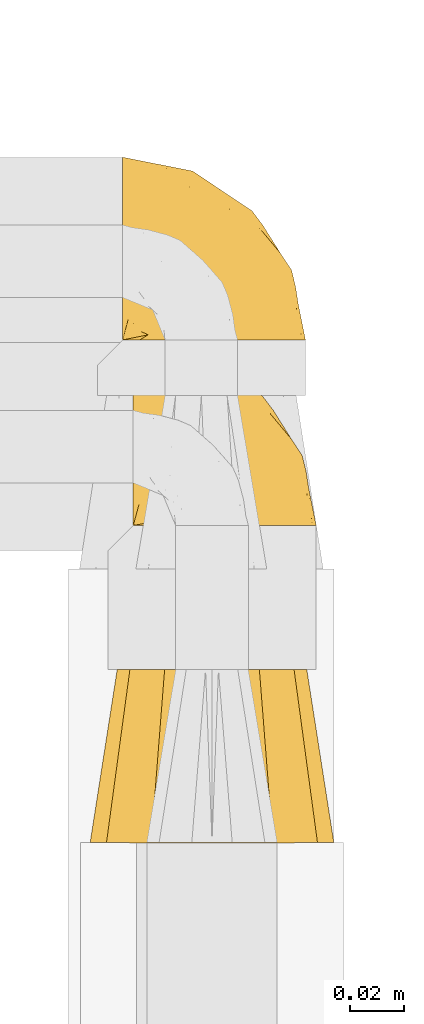
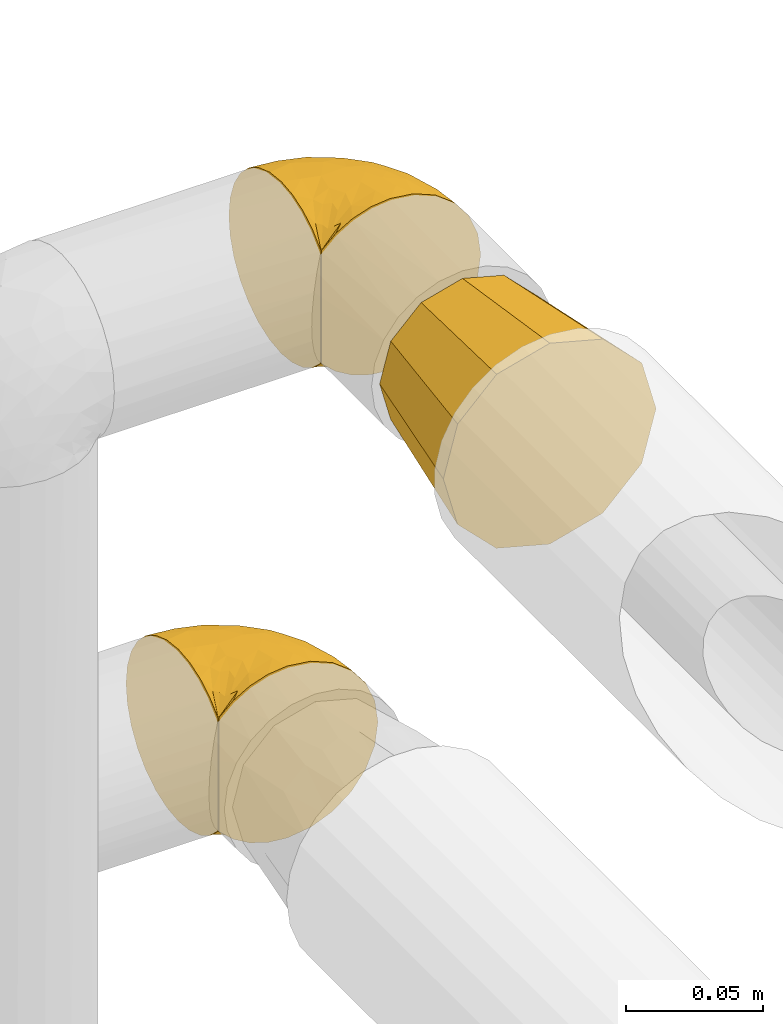
# One storey, part 116 of 827: 3 coverings.
"""IFC2X3 building model written with IfcOpenShell, lengths in millimetres."""

from ifc_helpers import new_model, entity, si_unit, converted_unit, derived_unit, direction, frame, origin, place, context, subcontext, project, spatial, faceted_brep, element, save


model = new_model("IFC2X3")

# Units and contexts
model_context = context("Model", 3, precision=0.01, world=origin(), true_north=direction((6.12303176911189e-17, 1.0)))
body_context = subcontext(model_context, "Body", "Model", "MODEL_VIEW")
ifc_project = project(units=[si_unit("LENGTHUNIT", "METRE", prefix="MILLI"), si_unit("AREAUNIT", "SQUARE_METRE"), si_unit("VOLUMEUNIT", "CUBIC_METRE"), converted_unit("PLANEANGLEUNIT", "DEGREE", entity("IfcRatioMeasure", 0.0174532925199433), si_unit("PLANEANGLEUNIT", "RADIAN"), dimensions=[0, 0, 0, 0, 0, 0, 0]), si_unit("MASSUNIT", "GRAM", prefix="KILO"), derived_unit("MASSDENSITYUNIT", [(si_unit("MASSUNIT", "GRAM", prefix="KILO"), 1), (si_unit("LENGTHUNIT", "METRE"), -3)]), derived_unit("MOMENTOFINERTIAUNIT", [(si_unit("LENGTHUNIT", "METRE"), 4)]), si_unit("TIMEUNIT", "SECOND"), si_unit("FREQUENCYUNIT", "HERTZ"), si_unit("THERMODYNAMICTEMPERATUREUNIT", "DEGREE_CELSIUS"), derived_unit("THERMALTRANSMITTANCEUNIT", [(si_unit("MASSUNIT", "GRAM", prefix="KILO"), 1), (si_unit("THERMODYNAMICTEMPERATUREUNIT", "KELVIN"), -1), (si_unit("TIMEUNIT", "SECOND"), -3)]), derived_unit("VOLUMETRICFLOWRATEUNIT", [(si_unit("LENGTHUNIT", "METRE"), 3), (si_unit("TIMEUNIT", "SECOND"), -1)]), derived_unit("MASSFLOWRATEUNIT", [(si_unit("MASSUNIT", "GRAM", prefix="KILO"), 1), (si_unit("TIMEUNIT", "SECOND"), -1)]), derived_unit("ROTATIONALFREQUENCYUNIT", [(si_unit("TIMEUNIT", "SECOND"), -1)]), si_unit("ELECTRICCURRENTUNIT", "AMPERE"), si_unit("ELECTRICVOLTAGEUNIT", "VOLT"), si_unit("POWERUNIT", "WATT"), si_unit("FORCEUNIT", "NEWTON", prefix="KILO"), si_unit("ILLUMINANCEUNIT", "LUX"), si_unit("LUMINOUSFLUXUNIT", "LUMEN"), si_unit("LUMINOUSINTENSITYUNIT", "CANDELA"), derived_unit("USERDEFINED", [(si_unit("MASSUNIT", "GRAM", prefix="KILO"), -1), (si_unit("LENGTHUNIT", "METRE"), -2), (si_unit("TIMEUNIT", "SECOND"), 3), (si_unit("LUMINOUSFLUXUNIT", "LUMEN"), 1)]), derived_unit("LINEARVELOCITYUNIT", [(si_unit("LENGTHUNIT", "METRE"), 1), (si_unit("TIMEUNIT", "SECOND"), -1)]), si_unit("PRESSUREUNIT", "PASCAL"), derived_unit("USERDEFINED", [(si_unit("LENGTHUNIT", "METRE"), -2), (si_unit("MASSUNIT", "GRAM", prefix="KILO"), 1), (si_unit("TIMEUNIT", "SECOND"), -2)]), derived_unit("LINEARFORCEUNIT", [(si_unit("MASSUNIT", "GRAM", prefix="KILO"), 1), (si_unit("LENGTHUNIT", "METRE"), 1), (si_unit("TIMEUNIT", "SECOND"), -2), (si_unit("LENGTHUNIT", "METRE"), -1)]), derived_unit("PLANARFORCEUNIT", [(si_unit("MASSUNIT", "GRAM", prefix="KILO"), 1), (si_unit("LENGTHUNIT", "METRE"), 1), (si_unit("TIMEUNIT", "SECOND"), -2), (si_unit("LENGTHUNIT", "METRE"), -2)])], contexts=[model_context])

# Site, building, storey
site_placement = place(None, origin())
site = spatial("IfcSite", under=ifc_project, at=site_placement, CompositionType="ELEMENT")
building_placement = place(site_placement, origin())
building = spatial("IfcBuilding", under=site, at=building_placement, CompositionType="ELEMENT")
storey_placement = place(building_placement, frame((0.0, 0.0, 28200.0)))
storey = spatial("IfcBuildingStorey", under=building, at=storey_placement, Name="08", CompositionType="ELEMENT", Elevation=28200.0)

# Coverings
covering_1_placement = place(storey_placement, frame((22837.6, 11846.71, 1507.53)))
element("IfcCovering", 1, at=covering_1_placement, inside=storey, Name=":ADSK_", ObjectType=":ADSK_", PredefinedType="INSULATION", context=body_context, shape_type="Brep", body=[
    faceted_brep([(1.6, 47.39, 74.81), (1.6, 54.7, 70.25), (1.6, 60.8, 64.17), (1.6, 65.4, 56.89), (1.6, 68.26, 48.78), (1.6, 69.25, 40.23), (1.6, 68.31, 31.67), (1.6, 65.48, 23.53), (1.6, 60.92, 16.23), (1.6, 54.85, 10.12), (1.6, 47.57, 5.52), (1.6, 39.45, 2.66), (1.6, 30.9, 1.67), (1.6, 22.8, 2.52), (1.6, 15.06, 5.04), (1.6, 8.03, 9.14), (1.6, 2.02, 14.62), (1.6, 2.01, 16.82), (1.6, 2.01, 18.56), (1.6, 2.0, 20.52), (1.6, 2.0, 22.49), (1.6, 1.99, 24.46), (1.6, 1.99, 26.42), (1.6, 1.98, 28.39), (1.6, 1.98, 30.36), (1.6, 1.97, 32.55), (1.6, 1.97, 34.75), (1.6, 1.96, 36.94), (1.6, 1.95, 39.13), (1.6, 1.95, 41.33), (1.6, 1.94, 43.52), (1.6, 1.94, 45.72), (1.6, 1.93, 47.91), (1.6, 1.92, 50.11), (1.6, 1.92, 52.3), (1.6, 1.91, 54.5), (1.6, 1.91, 56.69), (1.6, 1.9, 58.88), (1.6, 1.9, 61.08), (1.6, 1.89, 63.27), (1.6, 1.88, 65.47), (1.6, 7.87, 70.99), (1.6, 14.89, 75.13), (1.6, 22.61, 77.69), (1.6, 30.7, 78.57), (1.6, 39.26, 77.63), (1.85, 1.77, 14.62), (7.85, 1.78, 9.12), (14.87, 1.79, 5.0), (22.6, 1.8, 2.46), (30.7, 1.8, 1.6), (40.65, 1.8, 2.91), (49.92, 1.79, 6.75), (57.88, 1.77, 12.86), (63.99, 1.75, 20.82), (67.84, 1.73, 30.09), (69.15, 1.7, 40.05), (67.84, 1.67, 50.0), (63.99, 1.65, 59.27), (57.88, 1.63, 67.23), (49.92, 1.61, 73.34), (40.65, 1.6, 77.18), (30.7, 1.6, 78.49), (22.6, 1.6, 77.63), (14.87, 1.6, 75.09), (7.85, 1.62, 70.97), (1.85, 1.63, 65.47), (1.85, 1.64, 63.27), (1.85, 1.64, 62.29), (1.85, 1.64, 60.7), (1.85, 1.65, 59.11), (1.85, 1.65, 57.52), (1.85, 1.66, 55.93), (1.85, 1.66, 54.34), (1.85, 1.66, 52.76), (1.85, 1.67, 51.17), (1.85, 1.67, 49.58), (1.85, 1.68, 47.99), (1.85, 1.68, 46.4), (1.85, 1.69, 44.81), (1.85, 1.69, 43.22), (1.85, 1.7, 41.63), (1.85, 1.7, 40.05), (1.85, 1.7, 38.46), (1.85, 1.71, 36.87), (1.85, 1.71, 35.28), (1.85, 1.72, 33.69), (1.85, 1.72, 32.1), (1.85, 1.73, 30.51), (1.85, 1.73, 28.92), (1.85, 1.73, 27.33), (1.85, 1.74, 25.37), (1.85, 1.74, 23.4), (1.85, 1.75, 21.21), (1.85, 1.76, 19.01), (1.85, 1.76, 16.82), (1.77, 1.87, 42.32), (1.78, 1.86, 44.02), (1.77, 1.86, 47.13), (1.77, 1.85, 48.74), (1.76, 1.94, 23.57), (1.77, 1.93, 25.13), (1.79, 1.81, 61.34), (1.78, 1.92, 22.02), (1.78, 1.9, 29.72), (1.78, 1.82, 56.73), (1.78, 1.83, 55.14), (1.78, 1.88, 37.66), (1.74, 1.84, 64.12), (1.78, 1.9, 28.13), (1.78, 1.91, 26.62), (1.77, 1.91, 31.46), (1.78, 1.94, 16.16), (1.78, 1.87, 39.16), (1.78, 1.84, 50.37), (1.77, 1.94, 17.69), (1.77, 1.94, 19.17), (1.77, 1.82, 62.78), (1.78, 1.82, 58.35), (1.78, 1.85, 45.53), (1.77, 1.83, 59.91), (1.77, 1.81, 65.47), (1.72, 1.83, 65.47), (1.66, 1.86, 65.47), (1.77, 1.95, 14.62), (1.8, 1.89, 14.62), (1.82, 1.83, 14.62), (1.79, 1.92, 20.59), (1.78, 1.89, 32.99), (1.79, 1.88, 34.48), (1.78, 1.84, 51.91), (1.82, 1.7, 65.47), (1.8, 1.75, 65.47), (1.76, 1.85, 53.48), (1.66, 1.99, 14.62), (1.72, 1.97, 14.62), (1.78, 1.87, 40.77), (1.77, 1.89, 35.97), (9.41, 3.91, 7.84), (17.65, 7.62, 3.54), (7.41, 6.32, 8.33), (21.47, 21.68, 1.65), (15.21, 19.54, 2.24), (16.15, 27.0, 1.66), (28.75, 9.08, 1.61), (13.67, 9.4, 4.59), (12.79, 12.99, 3.99), (19.18, 14.82, 2.31), (29.16, 7.55, 1.61), (9.04, 5.53, 7.7), (7.41, 17.84, 3.57), (5.74, 7.89, 8.33), (3.72, 9.6, 7.86), (8.87, 28.95, 1.67), (26.8, 16.35, 1.63), (9.53, 14.34, 4.37), (7.34, 29.36, 1.67), (37.63, 57.16, 29.78), (17.92, 65.05, 27.51), (27.45, 64.11, 40.21), (37.01, 12.12, 2.42), (34.22, 19.37, 2.47), (45.87, 28.84, 9.15), (56.57, 24.79, 16.7), (52.31, 15.37, 9.58), (42.07, 18.56, 4.57), (44.74, 9.4, 4.54), (21.49, 47.17, 7.61), (11.02, 50.43, 7.62), (15.64, 56.27, 13.0), (26.02, 29.18, 2.43), (36.59, 54.61, 22.81), (65.49, 21.46, 32.95), (63.99, 18.55, 25.38), (15.2, 66.54, 40.22), (60.27, 12.24, 16.67), (45.25, 45.64, 20.11), (35.21, 50.73, 16.51), (22.52, 36.24, 3.36), (12.03, 42.27, 3.86), (13.32, 62.28, 19.75), (35.9, 37.56, 7.59), (33.87, 29.59, 4.11), (25.73, 53.77, 14.08), (26.34, 58.22, 19.74), (46.78, 49.4, 28.34), (59.54, 29.78, 24.82), (60.18, 33.34, 31.51), (53.93, 40.24, 26.31), (53.36, 44.2, 33.47), (49.36, 49.46, 40.17), (38.4, 56.79, 40.19), (66.44, 15.3, 40.08), (50.09, 35.74, 16.23), (41.08, 41.88, 12.96), (31.14, 46.58, 10.59), (28.19, 41.61, 6.6), (64.0, 27.55, 40.12), (56.68, 38.51, 40.14), (43.9, 13.0, 75.6), (65.46, 21.41, 47.43), (52.22, 42.96, 53.02), (37.61, 57.11, 50.61), (15.64, 56.14, 67.38), (13.31, 62.18, 60.66), (50.02, 21.91, 70.6), (59.28, 16.66, 63.49), (53.05, 32.95, 62.7), (21.48, 47.01, 72.72), (11.01, 50.27, 72.73), (12.03, 42.08, 76.45), (41.02, 49.97, 59.47), (35.39, 15.6, 77.8), (26.8, 16.15, 78.53), (28.75, 8.87, 78.51), (7.34, 29.16, 78.57), (65.81, 13.23, 53.19), (53.28, 10.85, 70.57), (59.8, 33.88, 48.97), (61.82, 25.08, 54.82), (17.91, 64.99, 52.91), (41.4, 32.85, 72.01), (40.48, 20.57, 75.84), (26.34, 58.12, 60.65), (31.68, 21.46, 77.92), (27.68, 28.1, 77.71), (16.15, 26.8, 78.56), (21.47, 21.47, 78.55), (28.05, 51.32, 67.36), (22.54, 36.05, 76.92), (8.87, 28.75, 78.57), (37.3, 8.46, 77.82), (41.07, 41.76, 67.34), (32.24, 39.28, 73.31), (47.4, 33.59, 67.75), (35.77, 27.29, 76.06), (17.65, 7.42, 76.58), (11.06, 3.52, 73.22), (8.55, 4.69, 71.94), (6.63, 5.54, 71.08), (12.77, 8.76, 75.1), (12.79, 12.79, 76.16), (7.41, 17.66, 76.61), (18.97, 13.9, 77.73), (3.72, 9.43, 72.28), (5.76, 7.7, 71.79), (15.21, 19.34, 77.95), (9.52, 14.14, 75.78)], [[[0, 1, 2, 3, 4, 5, 6, 7, 8, 9, 10, 11, 12, 13, 14, 15, 16, 17, 18, 19, 20, 21, 22, 23, 24, 25, 26, 27, 28, 29, 30, 31, 32, 33, 34, 35, 36, 37, 38, 39, 40, 41, 42, 43, 44, 45]], [[46, 47, 48, 49, 50, 51, 52, 53, 54, 55, 56, 57, 58, 59, 60, 61, 62, 63, 64, 65, 66, 67, 68, 69, 70, 71, 72, 73, 74, 75, 76, 77, 78, 79, 80, 81, 82, 83, 84, 85, 86, 87, 88, 89, 90, 91, 92, 93, 94, 95]], [[96, 97, 30]], [[98, 77, 99]], [[100, 101, 21]], [[69, 68, 102]], [[20, 19, 103]], [[24, 23, 104]], [[20, 103, 100]], [[72, 105, 106]], [[84, 83, 107]], [[89, 88, 104]], [[108, 67, 66]], [[109, 110, 90]], [[111, 25, 24]], [[112, 17, 16]], [[82, 113, 83]], [[109, 23, 22]], [[114, 76, 75]], [[105, 36, 106]], [[104, 111, 24]], [[18, 115, 116]], [[97, 96, 80]], [[67, 108, 117]], [[105, 71, 118]], [[31, 97, 119]], [[102, 120, 69]], [[108, 121, 122, 123, 40]], [[112, 95, 115]], [[17, 115, 18]], [[94, 116, 115]], [[117, 68, 67]], [[38, 117, 39]], [[112, 124, 125, 126, 46]], [[17, 112, 115]], [[70, 120, 118]], [[39, 117, 108]], [[120, 38, 37]], [[120, 37, 118]], [[120, 70, 69]], [[116, 94, 127]], [[128, 86, 129]], [[117, 38, 102]], [[74, 130, 75]], [[99, 33, 32]], [[115, 95, 94]], [[39, 108, 40]], [[108, 66, 131, 132, 121]], [[105, 72, 71]], [[118, 37, 36]], [[71, 70, 118]], [[35, 106, 36]], [[36, 105, 118]], [[35, 133, 106]], [[74, 73, 133]], [[106, 133, 73]], [[99, 114, 33]], [[133, 35, 34]], [[73, 72, 106]], [[95, 112, 46]], [[112, 16, 134, 135, 124]], [[130, 114, 75]], [[99, 76, 114]], [[114, 130, 33]], [[34, 33, 130]], [[78, 77, 98]], [[98, 119, 78]], [[130, 133, 34]], [[133, 130, 74]], [[79, 97, 80]], [[98, 99, 32]], [[98, 32, 31]], [[77, 76, 99]], [[97, 79, 119]], [[136, 96, 29]], [[30, 97, 31]], [[136, 29, 28]], [[81, 80, 96]], [[29, 96, 30]], [[31, 119, 98]], [[119, 79, 78]], [[96, 136, 81]], [[82, 81, 136]], [[113, 107, 83]], [[84, 107, 137]], [[107, 27, 137]], [[113, 28, 107]], [[27, 107, 28]], [[85, 84, 137]], [[137, 27, 26]], [[113, 136, 28]], [[136, 113, 82]], [[109, 89, 104]], [[86, 85, 129]], [[89, 109, 90]], [[111, 87, 128]], [[26, 129, 137]], [[88, 111, 104]], [[25, 111, 128]], [[22, 110, 109]], [[23, 109, 104]], [[110, 91, 90]], [[100, 92, 101]], [[110, 22, 101]], [[91, 110, 101]], [[116, 19, 18]], [[111, 88, 87]], [[127, 103, 19]], [[25, 128, 26]], [[86, 128, 87]], [[128, 129, 26]], [[137, 129, 85]], [[120, 102, 38]], [[117, 102, 68]], [[91, 101, 92]], [[21, 101, 22]], [[93, 92, 103]], [[100, 21, 20]], [[100, 103, 92]], [[127, 93, 103]], [[93, 127, 94]], [[116, 127, 19]], [[126, 138, 47]], [[48, 138, 139]], [[140, 125, 124]], [[141, 142, 143]], [[144, 49, 139]], [[145, 140, 146]], [[48, 139, 49]], [[139, 145, 147]], [[49, 144, 148, 50]], [[126, 125, 149]], [[14, 13, 150]], [[151, 146, 140]], [[149, 140, 145]], [[152, 151, 135]], [[152, 14, 150]], [[16, 15, 134]], [[13, 153, 150]], [[124, 151, 140]], [[141, 147, 142]], [[14, 152, 15]], [[15, 152, 134]], [[47, 46, 126]], [[139, 154, 144]], [[138, 48, 47]], [[125, 140, 149]], [[135, 134, 152]], [[146, 155, 142]], [[145, 146, 147]], [[149, 139, 138]], [[147, 141, 154]], [[147, 146, 142]], [[139, 147, 154]], [[139, 149, 145]], [[149, 138, 126]], [[155, 146, 151]], [[150, 143, 142]], [[152, 155, 151]], [[150, 142, 155]], [[13, 12, 156, 153]], [[153, 143, 150]], [[152, 150, 155]], [[151, 124, 135]], [[157, 158, 159]], [[160, 154, 161]], [[162, 163, 164]], [[165, 166, 160]], [[167, 168, 169]], [[141, 170, 161]], [[156, 12, 11]], [[158, 157, 171]], [[172, 55, 173]], [[158, 6, 174]], [[175, 54, 53]], [[52, 166, 164]], [[52, 164, 53]], [[54, 175, 173]], [[166, 52, 51]], [[176, 177, 171]], [[178, 143, 179]], [[156, 11, 179]], [[8, 7, 180]], [[169, 9, 8]], [[179, 143, 153, 156]], [[179, 11, 10]], [[168, 179, 10]], [[181, 162, 182]], [[179, 167, 178]], [[183, 184, 177]], [[183, 169, 184]], [[176, 171, 185]], [[172, 186, 187]], [[158, 7, 6]], [[159, 158, 174]], [[184, 180, 158]], [[54, 173, 55]], [[180, 169, 8]], [[188, 189, 187]], [[9, 168, 10]], [[186, 188, 187]], [[190, 157, 159, 191]], [[55, 172, 192]], [[176, 193, 194]], [[161, 170, 182]], [[162, 164, 165]], [[175, 164, 163]], [[51, 50, 148]], [[167, 195, 196]], [[178, 182, 170]], [[6, 5, 174]], [[158, 180, 7]], [[169, 180, 184]], [[169, 168, 9]], [[179, 168, 167]], [[182, 162, 165]], [[162, 194, 193]], [[161, 165, 160]], [[195, 181, 196]], [[192, 172, 197]], [[192, 56, 55]], [[189, 190, 198]], [[198, 197, 187]], [[172, 187, 197]], [[185, 189, 188]], [[198, 187, 189]], [[186, 172, 173]], [[173, 163, 186]], [[193, 186, 163]], [[176, 185, 188]], [[185, 157, 190]], [[188, 186, 193]], [[177, 176, 194]], [[188, 193, 176]], [[162, 193, 163]], [[195, 177, 194]], [[171, 177, 184]], [[181, 195, 194]], [[183, 167, 169]], [[162, 181, 194]], [[196, 182, 178]], [[158, 171, 184]], [[171, 157, 185]], [[177, 195, 183]], [[167, 183, 195]], [[182, 196, 181]], [[178, 170, 143]], [[178, 167, 196]], [[164, 175, 53]], [[173, 175, 163]], [[160, 51, 148]], [[164, 166, 165]], [[51, 160, 166]], [[160, 148, 144, 154]], [[141, 161, 154]], [[182, 165, 161]], [[190, 189, 185]], [[143, 170, 141]], [[60, 199, 61]], [[197, 200, 192]], [[201, 190, 202]], [[200, 57, 192]], [[203, 204, 2]], [[205, 206, 207]], [[208, 209, 210]], [[211, 207, 201]], [[212, 213, 214]], [[45, 215, 210]], [[216, 206, 58]], [[45, 44, 215]], [[59, 217, 60]], [[60, 217, 199]], [[0, 45, 210]], [[218, 201, 219]], [[202, 159, 220]], [[205, 221, 222]], [[223, 204, 203]], [[1, 203, 2]], [[57, 200, 216]], [[220, 3, 204]], [[220, 174, 4]], [[1, 0, 209]], [[212, 224, 213]], [[225, 226, 227]], [[228, 223, 203]], [[208, 210, 229]], [[210, 226, 229]], [[3, 220, 4]], [[58, 206, 59]], [[209, 203, 1]], [[202, 220, 223]], [[228, 203, 208]], [[202, 211, 201]], [[3, 2, 204]], [[202, 190, 191, 159]], [[210, 215, 230, 226]], [[199, 212, 231]], [[232, 233, 221]], [[233, 208, 229]], [[207, 206, 219]], [[217, 206, 205]], [[227, 224, 225]], [[233, 232, 228]], [[201, 207, 219]], [[234, 232, 221]], [[218, 219, 200]], [[202, 223, 211]], [[174, 220, 159]], [[174, 5, 4]], [[61, 231, 62]], [[220, 204, 223]], [[210, 209, 0]], [[203, 209, 208]], [[225, 233, 229]], [[224, 227, 213]], [[221, 233, 235]], [[57, 56, 192]], [[198, 218, 197]], [[200, 219, 216]], [[201, 198, 190]], [[197, 218, 200]], [[198, 201, 218]], [[206, 216, 219]], [[58, 57, 216]], [[231, 212, 214]], [[222, 212, 199]], [[228, 211, 223]], [[207, 211, 232]], [[62, 231, 214]], [[199, 231, 61]], [[233, 228, 208]], [[211, 228, 232]], [[222, 221, 235]], [[234, 205, 207]], [[206, 217, 59]], [[199, 217, 205]], [[205, 222, 199]], [[224, 222, 235]], [[222, 224, 212]], [[224, 235, 225]], [[233, 225, 235]], [[226, 225, 229]], [[205, 234, 221]], [[207, 232, 234]], [[63, 214, 236]], [[214, 213, 236]], [[214, 63, 62]], [[237, 236, 238]], [[238, 132, 131]], [[236, 237, 64]], [[239, 240, 241]], [[63, 236, 64]], [[131, 66, 65]], [[237, 131, 65]], [[242, 230, 43]], [[237, 65, 64]], [[239, 121, 132]], [[42, 242, 43]], [[241, 240, 243]], [[41, 123, 244]], [[43, 230, 215, 44]], [[244, 122, 245]], [[227, 246, 243]], [[241, 247, 245]], [[121, 239, 245]], [[41, 40, 123]], [[132, 238, 239]], [[244, 42, 41]], [[131, 237, 238]], [[240, 239, 238]], [[245, 239, 241]], [[247, 241, 246]], [[247, 244, 245]], [[238, 236, 240]], [[243, 236, 213]], [[236, 243, 240]], [[227, 226, 246]], [[243, 213, 227]], [[242, 246, 226]], [[243, 246, 241]], [[246, 242, 247]], [[244, 247, 242]], [[242, 226, 230]], [[42, 244, 242]], [[122, 244, 123]], [[122, 121, 245]]]),
])
covering_2_placement = place(storey_placement, frame((22821.7, 11731.15, 1500.8)))
element("IfcCovering", 2, at=covering_2_placement, inside=storey, Name=":ADSK_", ObjectType=":ADSK_", PredefinedType="INSULATION", context=body_context, shape_type="Brep", body=[
    faceted_brep([(15.86, 0.04, 77.33), (7.62, 0.06, 69.1), (5.02, 0.09, 59.38), (1.6, 0.12, 46.6), (5.02, 0.16, 33.81), (7.62, 0.18, 24.1), (15.86, 0.2, 15.86), (24.1, 0.23, 7.62), (33.81, 0.23, 5.02), (46.6, 0.24, 1.6), (59.38, 0.23, 5.02), (69.1, 0.23, 7.62), (77.33, 0.2, 15.86), (85.57, 0.18, 24.1), (88.17, 0.16, 33.81), (91.6, 0.12, 46.6), (88.17, 0.09, 59.38), (85.57, 0.06, 69.1), (77.33, 0.04, 77.33), (69.1, 0.02, 85.57), (59.38, 0.01, 88.17), (46.6, 0.0, 91.59), (33.81, 0.01, 88.17), (24.1, 0.02, 85.57), (64.1, 64.04, 77.08), (70.5, 64.06, 70.67), (76.91, 64.07, 64.27), (79.25, 64.1, 55.52), (81.6, 64.12, 46.77), (79.25, 64.15, 38.02), (76.91, 64.17, 29.27), (70.5, 64.19, 22.86), (64.1, 64.2, 16.46), (55.35, 64.21, 14.11), (46.6, 64.22, 11.77), (37.85, 64.21, 14.11), (29.1, 64.2, 16.46), (22.69, 64.19, 22.86), (16.28, 64.17, 29.27), (13.94, 64.15, 38.02), (11.6, 64.12, 46.77), (13.94, 64.1, 55.52), (16.28, 64.07, 64.27), (22.69, 64.06, 70.67), (29.1, 64.04, 77.08), (37.85, 64.03, 79.42), (46.6, 64.03, 81.77), (55.35, 64.03, 79.42)], [[[0, 1, 2, 3, 4, 5, 6, 7, 8, 9, 10, 11, 12, 13, 14, 15, 16, 17, 18, 19, 20, 21, 22, 23]], [[24, 25, 26, 27, 28, 29, 30, 31, 32, 33, 34, 35, 36, 37, 38, 39, 40, 41, 42, 43, 44, 45, 46, 47]], [[38, 5, 4, 3, 40, 39]], [[6, 5, 38, 37, 36, 7]], [[35, 34, 9, 8, 7, 36]], [[32, 11, 10, 9, 34, 33]], [[12, 11, 32, 31, 30, 13]], [[29, 28, 15, 14, 13, 30]], [[26, 17, 16, 15, 28, 27]], [[18, 17, 26, 25, 24, 19]], [[47, 46, 21, 20, 19, 24]], [[44, 23, 22, 21, 46, 45]], [[0, 23, 44, 43, 42, 1]], [[41, 40, 3, 2, 1, 42]]]),
])
covering_3_placement = place(storey_placement, frame((22833.67, 11915.3, 1258.27)))
element("IfcCovering", 3, at=covering_3_placement, inside=storey, Name=":ADSK_", ObjectType=":ADSK_", PredefinedType="INSULATION", context=body_context, shape_type="Brep", body=[
    faceted_brep([(1.6, 47.38, 74.68), (1.6, 54.67, 70.1), (1.6, 60.76, 64.01), (1.6, 65.34, 56.72), (1.6, 68.18, 48.6), (1.6, 69.15, 40.05), (1.6, 68.18, 31.49), (1.6, 65.33, 23.36), (1.6, 60.75, 16.07), (1.6, 54.66, 9.98), (1.6, 47.37, 5.4), (1.6, 39.25, 2.56), (1.6, 30.7, 1.6), (1.6, 22.59, 2.46), (1.6, 14.86, 5.01), (1.6, 7.84, 9.13), (1.6, 1.85, 14.62), (1.6, 1.85, 16.82), (1.6, 1.85, 18.56), (1.6, 1.85, 20.52), (1.6, 1.85, 22.49), (1.6, 1.85, 24.46), (1.6, 1.85, 26.42), (1.6, 1.85, 28.39), (1.6, 1.85, 30.36), (1.6, 1.85, 32.55), (1.6, 1.85, 34.75), (1.6, 1.85, 36.94), (1.6, 1.85, 39.13), (1.6, 1.85, 41.33), (1.6, 1.85, 43.52), (1.6, 1.85, 45.72), (1.6, 1.85, 47.91), (1.6, 1.85, 50.11), (1.6, 1.85, 52.3), (1.6, 1.85, 54.49), (1.6, 1.85, 56.69), (1.6, 1.85, 58.88), (1.6, 1.85, 61.08), (1.6, 1.85, 63.27), (1.6, 1.85, 65.47), (1.6, 7.85, 70.97), (1.6, 14.88, 75.09), (1.6, 22.61, 77.64), (1.6, 30.7, 78.5), (1.6, 39.26, 77.53), (1.85, 1.6, 14.62), (7.85, 1.6, 9.12), (14.87, 1.6, 5.0), (22.6, 1.6, 2.46), (30.7, 1.6, 1.6), (40.65, 1.6, 2.91), (49.92, 1.6, 6.75), (57.88, 1.6, 12.86), (63.99, 1.6, 20.82), (67.84, 1.6, 30.09), (69.15, 1.6, 40.05), (67.84, 1.6, 50.0), (63.99, 1.6, 59.27), (57.88, 1.6, 67.23), (49.92, 1.6, 73.34), (40.65, 1.6, 77.19), (30.7, 1.6, 78.5), (22.6, 1.6, 77.63), (14.87, 1.6, 75.09), (7.85, 1.6, 70.97), (1.85, 1.6, 65.47), (1.85, 1.6, 63.27), (1.85, 1.6, 62.29), (1.85, 1.6, 60.7), (1.85, 1.6, 59.11), (1.85, 1.6, 57.52), (1.85, 1.6, 55.93), (1.85, 1.6, 54.34), (1.85, 1.6, 52.76), (1.85, 1.6, 51.17), (1.85, 1.6, 49.58), (1.85, 1.6, 47.99), (1.85, 1.6, 46.4), (1.85, 1.6, 44.81), (1.85, 1.6, 43.22), (1.85, 1.6, 41.63), (1.85, 1.6, 40.05), (1.85, 1.6, 38.46), (1.85, 1.6, 36.87), (1.85, 1.6, 35.28), (1.85, 1.6, 33.69), (1.85, 1.6, 32.1), (1.85, 1.6, 30.51), (1.85, 1.6, 28.92), (1.85, 1.6, 27.33), (1.85, 1.6, 25.37), (1.85, 1.6, 23.4), (1.85, 1.6, 21.21), (1.85, 1.6, 19.01), (1.85, 1.6, 16.82), (1.77, 1.78, 42.32), (1.78, 1.77, 44.02), (1.77, 1.78, 47.13), (1.77, 1.77, 48.74), (1.76, 1.79, 23.57), (1.77, 1.78, 25.13), (1.79, 1.76, 61.34), (1.78, 1.77, 22.02), (1.78, 1.77, 29.72), (1.78, 1.76, 56.73), (1.78, 1.77, 55.14), (1.78, 1.77, 37.66), (1.74, 1.8, 64.12), (1.78, 1.76, 28.13), (1.78, 1.77, 26.62), (1.77, 1.78, 31.46), (1.78, 1.77, 16.16), (1.78, 1.77, 39.16), (1.78, 1.76, 50.37), (1.77, 1.77, 17.69), (1.77, 1.78, 19.17), (1.77, 1.77, 62.78), (1.78, 1.77, 58.35), (1.78, 1.77, 45.53), (1.77, 1.78, 59.91), (1.77, 1.77, 65.47), (1.72, 1.8, 65.47), (1.66, 1.82, 65.47), (1.77, 1.77, 14.62), (1.8, 1.72, 14.62), (1.82, 1.66, 14.62), (1.79, 1.76, 20.59), (1.78, 1.77, 32.99), (1.79, 1.76, 34.48), (1.78, 1.77, 51.91), (1.82, 1.66, 65.47), (1.8, 1.72, 65.47), (1.76, 1.78, 53.48), (1.66, 1.82, 14.62), (1.72, 1.8, 14.62), (1.78, 1.77, 40.77), (1.77, 1.78, 35.97), (9.41, 3.72, 7.84), (17.65, 7.41, 3.53), (7.41, 6.13, 8.32), (15.21, 19.34, 2.19), (7.41, 17.64, 3.53), (16.15, 26.8, 1.6), (28.75, 8.87, 1.6), (13.67, 9.2, 4.57), (12.79, 12.79, 3.96), (19.18, 14.62, 2.28), (29.16, 7.34, 1.6), (9.04, 5.33, 7.69), (5.74, 7.7, 8.32), (3.72, 9.41, 7.84), (8.87, 28.75, 1.6), (21.47, 21.47, 1.6), (26.8, 16.15, 1.6), (9.53, 14.14, 4.34), (7.34, 29.16, 1.6), (37.63, 57.02, 29.63), (17.92, 64.92, 27.34), (27.45, 64.0, 40.05), (37.01, 11.92, 2.39), (34.22, 19.16, 2.43), (45.87, 28.65, 9.07), (56.57, 24.62, 16.64), (52.31, 15.19, 9.54), (42.07, 18.36, 4.52), (44.74, 9.2, 4.52), (21.49, 46.98, 7.49), (11.02, 50.24, 7.49), (15.64, 56.1, 12.85), (26.02, 28.97, 2.35), (36.59, 54.46, 22.66), (65.49, 21.34, 32.9), (63.99, 18.4, 25.33), (15.2, 66.44, 40.05), (60.27, 12.07, 16.64), (45.25, 45.49, 19.99), (35.21, 50.57, 16.37), (22.52, 36.04, 3.26), (12.03, 42.07, 3.75), (13.32, 62.12, 19.58), (35.9, 37.37, 7.5), (33.87, 29.39, 4.04), (25.73, 53.59, 13.94), (26.34, 58.06, 19.58), (46.78, 49.27, 28.21), (59.54, 29.63, 24.75), (60.18, 33.21, 31.42), (53.93, 40.1, 26.2), (53.36, 44.08, 33.36), (49.36, 49.36, 40.05), (38.4, 56.68, 40.05), (66.44, 15.2, 40.05), (50.09, 35.57, 16.14), (41.08, 41.7, 12.85), (31.14, 46.4, 10.47), (28.19, 41.41, 6.49), (64.0, 27.45, 40.05), (56.68, 38.4, 40.05), (43.9, 12.99, 75.57), (65.46, 21.33, 47.37), (52.22, 42.89, 52.91), (37.61, 57.04, 50.46), (15.64, 56.11, 67.23), (13.31, 62.13, 60.5), (50.02, 21.89, 70.55), (59.28, 16.62, 63.45), (53.05, 32.9, 62.61), (21.48, 46.99, 72.6), (11.01, 50.25, 72.6), (12.03, 42.08, 76.34), (41.02, 49.91, 59.34), (35.39, 15.6, 77.76), (26.8, 16.15, 78.5), (28.75, 8.87, 78.5), (7.34, 29.16, 78.5), (65.81, 13.16, 53.16), (53.28, 10.83, 70.55), (59.8, 33.8, 48.88), (61.82, 25.02, 54.76), (17.91, 64.92, 52.74), (41.4, 32.83, 71.93), (40.48, 20.56, 75.79), (26.34, 58.07, 60.5), (31.68, 21.46, 77.86), (27.68, 28.1, 77.64), (16.15, 26.8, 78.5), (21.47, 21.47, 78.5), (28.05, 51.29, 67.23), (22.54, 36.04, 76.82), (8.87, 28.75, 78.5), (37.3, 8.45, 77.8), (41.07, 41.73, 67.23), (32.24, 39.27, 73.2), (47.4, 33.56, 67.66), (35.77, 27.29, 75.99), (17.65, 7.41, 76.57), (11.06, 3.51, 73.21), (8.55, 4.68, 71.93), (6.63, 5.52, 71.07), (12.77, 8.75, 75.09), (12.79, 12.79, 76.13), (7.41, 17.65, 76.57), (18.97, 13.9, 77.69), (3.72, 9.42, 72.26), (5.76, 7.68, 71.77), (15.21, 19.33, 77.9), (9.52, 14.13, 75.75)], [[[0, 1, 2, 3, 4, 5, 6, 7, 8, 9, 10, 11, 12, 13, 14, 15, 16, 17, 18, 19, 20, 21, 22, 23, 24, 25, 26, 27, 28, 29, 30, 31, 32, 33, 34, 35, 36, 37, 38, 39, 40, 41, 42, 43, 44, 45]], [[46, 47, 48, 49, 50, 51, 52, 53, 54, 55, 56, 57, 58, 59, 60, 61, 62, 63, 64, 65, 66, 67, 68, 69, 70, 71, 72, 73, 74, 75, 76, 77, 78, 79, 80, 81, 82, 83, 84, 85, 86, 87, 88, 89, 90, 91, 92, 93, 94, 95]], [[96, 97, 30]], [[98, 77, 99]], [[100, 101, 21]], [[69, 68, 102]], [[20, 19, 103]], [[24, 23, 104]], [[20, 103, 100]], [[72, 105, 106]], [[84, 83, 107]], [[89, 88, 104]], [[108, 67, 66]], [[109, 110, 90]], [[111, 25, 24]], [[112, 17, 16]], [[82, 113, 83]], [[109, 23, 22]], [[114, 76, 75]], [[105, 36, 106]], [[104, 111, 24]], [[18, 115, 116]], [[97, 96, 80]], [[67, 108, 117]], [[105, 71, 118]], [[31, 97, 119]], [[102, 120, 69]], [[108, 121, 122, 123, 40]], [[112, 95, 115]], [[17, 115, 18]], [[94, 116, 115]], [[117, 68, 67]], [[38, 117, 39]], [[112, 124, 125, 126, 46]], [[17, 112, 115]], [[70, 120, 118]], [[39, 117, 108]], [[120, 38, 37]], [[120, 37, 118]], [[120, 70, 69]], [[116, 94, 127]], [[128, 86, 129]], [[117, 38, 102]], [[74, 130, 75]], [[99, 33, 32]], [[115, 95, 94]], [[39, 108, 40]], [[108, 66, 131, 132, 121]], [[105, 72, 71]], [[118, 37, 36]], [[71, 70, 118]], [[35, 106, 36]], [[36, 105, 118]], [[35, 133, 106]], [[74, 73, 133]], [[106, 133, 73]], [[99, 114, 33]], [[133, 35, 34]], [[73, 72, 106]], [[95, 112, 46]], [[112, 16, 134, 135, 124]], [[130, 114, 75]], [[99, 76, 114]], [[114, 130, 33]], [[34, 33, 130]], [[78, 77, 98]], [[98, 119, 78]], [[130, 133, 34]], [[133, 130, 74]], [[79, 97, 80]], [[98, 99, 32]], [[98, 32, 31]], [[77, 76, 99]], [[97, 79, 119]], [[136, 96, 29]], [[30, 97, 31]], [[136, 29, 28]], [[81, 80, 96]], [[29, 96, 30]], [[31, 119, 98]], [[119, 79, 78]], [[96, 136, 81]], [[82, 81, 136]], [[113, 107, 83]], [[84, 107, 137]], [[107, 27, 137]], [[113, 28, 107]], [[27, 107, 28]], [[85, 84, 137]], [[137, 27, 26]], [[113, 136, 28]], [[136, 113, 82]], [[109, 89, 104]], [[86, 85, 129]], [[89, 109, 90]], [[111, 87, 128]], [[26, 129, 137]], [[88, 111, 104]], [[25, 111, 128]], [[22, 110, 109]], [[23, 109, 104]], [[110, 91, 90]], [[100, 92, 101]], [[110, 22, 101]], [[91, 110, 101]], [[116, 19, 18]], [[111, 88, 87]], [[127, 103, 19]], [[25, 128, 26]], [[86, 128, 87]], [[128, 129, 26]], [[137, 129, 85]], [[120, 102, 38]], [[117, 102, 68]], [[91, 101, 92]], [[21, 101, 22]], [[93, 92, 103]], [[100, 21, 20]], [[100, 103, 92]], [[127, 93, 103]], [[93, 127, 94]], [[116, 127, 19]], [[126, 138, 47]], [[48, 138, 139]], [[140, 125, 124]], [[141, 142, 143]], [[144, 49, 139]], [[145, 140, 146]], [[48, 139, 49]], [[139, 145, 147]], [[49, 144, 148, 50]], [[126, 125, 149]], [[14, 13, 142]], [[150, 146, 140]], [[149, 140, 145]], [[151, 150, 135]], [[151, 14, 142]], [[16, 15, 134]], [[13, 152, 142]], [[124, 150, 140]], [[141, 143, 153]], [[14, 151, 15]], [[15, 151, 134]], [[47, 46, 126]], [[139, 154, 144]], [[138, 48, 47]], [[125, 140, 149]], [[135, 134, 151]], [[146, 155, 141]], [[145, 146, 147]], [[149, 139, 138]], [[147, 153, 154]], [[147, 146, 141]], [[139, 147, 154]], [[139, 149, 145]], [[149, 138, 126]], [[147, 141, 153]], [[146, 150, 155]], [[151, 155, 150]], [[142, 141, 155]], [[13, 12, 156, 152]], [[152, 143, 142]], [[151, 142, 155]], [[150, 124, 135]], [[157, 158, 159]], [[160, 154, 161]], [[162, 163, 164]], [[165, 166, 160]], [[167, 168, 169]], [[153, 170, 161]], [[156, 12, 11]], [[158, 157, 171]], [[172, 55, 173]], [[158, 6, 174]], [[175, 54, 53]], [[52, 166, 164]], [[52, 164, 53]], [[54, 175, 173]], [[166, 52, 51]], [[176, 177, 171]], [[178, 143, 179]], [[156, 11, 179]], [[8, 7, 180]], [[169, 9, 8]], [[179, 143, 152, 156]], [[179, 11, 10]], [[168, 179, 10]], [[181, 162, 182]], [[179, 167, 178]], [[183, 184, 177]], [[183, 169, 184]], [[176, 171, 185]], [[172, 186, 187]], [[158, 7, 6]], [[159, 158, 174]], [[184, 180, 158]], [[54, 173, 55]], [[180, 169, 8]], [[188, 189, 187]], [[9, 168, 10]], [[186, 188, 187]], [[190, 157, 159, 191]], [[55, 172, 192]], [[176, 193, 194]], [[161, 170, 182]], [[162, 164, 165]], [[175, 164, 163]], [[51, 50, 148]], [[167, 195, 196]], [[178, 182, 170]], [[6, 5, 174]], [[158, 180, 7]], [[169, 180, 184]], [[169, 168, 9]], [[179, 168, 167]], [[182, 162, 165]], [[162, 194, 193]], [[161, 165, 160]], [[195, 181, 196]], [[192, 172, 197]], [[192, 56, 55]], [[189, 190, 198]], [[198, 197, 187]], [[172, 187, 197]], [[185, 189, 188]], [[198, 187, 189]], [[186, 172, 173]], [[173, 163, 186]], [[193, 186, 163]], [[176, 185, 188]], [[185, 157, 190]], [[188, 186, 193]], [[177, 176, 194]], [[188, 193, 176]], [[162, 193, 163]], [[195, 177, 194]], [[171, 177, 184]], [[181, 195, 194]], [[183, 167, 169]], [[162, 181, 194]], [[196, 182, 178]], [[158, 171, 184]], [[171, 157, 185]], [[177, 195, 183]], [[167, 183, 195]], [[182, 196, 181]], [[178, 170, 143]], [[178, 167, 196]], [[164, 175, 53]], [[173, 175, 163]], [[160, 51, 148]], [[164, 166, 165]], [[51, 160, 166]], [[160, 148, 144, 154]], [[153, 161, 154]], [[182, 165, 161]], [[190, 189, 185]], [[143, 170, 153]], [[60, 199, 61]], [[197, 200, 192]], [[201, 190, 202]], [[200, 57, 192]], [[203, 204, 2]], [[205, 206, 207]], [[208, 209, 210]], [[211, 207, 201]], [[212, 213, 214]], [[45, 215, 210]], [[216, 206, 58]], [[45, 44, 215]], [[59, 217, 60]], [[60, 217, 199]], [[0, 45, 210]], [[218, 201, 219]], [[202, 159, 220]], [[205, 221, 222]], [[223, 204, 203]], [[1, 203, 2]], [[57, 200, 216]], [[220, 3, 204]], [[220, 174, 4]], [[1, 0, 209]], [[212, 224, 213]], [[225, 226, 227]], [[228, 223, 203]], [[208, 210, 229]], [[210, 226, 229]], [[3, 220, 4]], [[58, 206, 59]], [[209, 203, 1]], [[202, 220, 223]], [[228, 203, 208]], [[202, 211, 201]], [[3, 2, 204]], [[202, 190, 191, 159]], [[210, 215, 230, 226]], [[199, 212, 231]], [[232, 233, 221]], [[233, 208, 229]], [[207, 206, 219]], [[217, 206, 205]], [[227, 224, 225]], [[233, 232, 228]], [[201, 207, 219]], [[234, 232, 221]], [[218, 219, 200]], [[202, 223, 211]], [[174, 220, 159]], [[174, 5, 4]], [[61, 231, 62]], [[220, 204, 223]], [[210, 209, 0]], [[203, 209, 208]], [[225, 233, 229]], [[224, 227, 213]], [[221, 233, 235]], [[57, 56, 192]], [[198, 218, 197]], [[200, 219, 216]], [[201, 198, 190]], [[197, 218, 200]], [[198, 201, 218]], [[206, 216, 219]], [[58, 57, 216]], [[231, 212, 214]], [[222, 212, 199]], [[228, 211, 223]], [[207, 211, 232]], [[62, 231, 214]], [[199, 231, 61]], [[233, 228, 208]], [[211, 228, 232]], [[222, 221, 235]], [[234, 205, 207]], [[206, 217, 59]], [[199, 217, 205]], [[205, 222, 199]], [[224, 222, 235]], [[222, 224, 212]], [[224, 235, 225]], [[233, 225, 235]], [[226, 225, 229]], [[205, 234, 221]], [[207, 232, 234]], [[63, 214, 236]], [[214, 213, 236]], [[214, 63, 62]], [[237, 236, 238]], [[238, 132, 131]], [[236, 237, 64]], [[239, 240, 241]], [[63, 236, 64]], [[131, 66, 65]], [[237, 131, 65]], [[242, 230, 43]], [[237, 65, 64]], [[239, 121, 132]], [[42, 242, 43]], [[241, 240, 243]], [[41, 123, 244]], [[43, 230, 215, 44]], [[244, 122, 245]], [[227, 246, 243]], [[241, 243, 246]], [[121, 239, 245]], [[41, 40, 123]], [[132, 238, 239]], [[244, 42, 41]], [[131, 237, 238]], [[240, 239, 238]], [[245, 239, 241]], [[247, 241, 246]], [[247, 244, 245]], [[238, 236, 240]], [[243, 236, 213]], [[236, 243, 240]], [[226, 246, 227]], [[243, 213, 227]], [[226, 242, 246]], [[241, 247, 245]], [[246, 242, 247]], [[244, 247, 242]], [[242, 226, 230]], [[42, 244, 242]], [[122, 244, 123]], [[122, 121, 245]]]),
])

save(model, "model.ifc")
